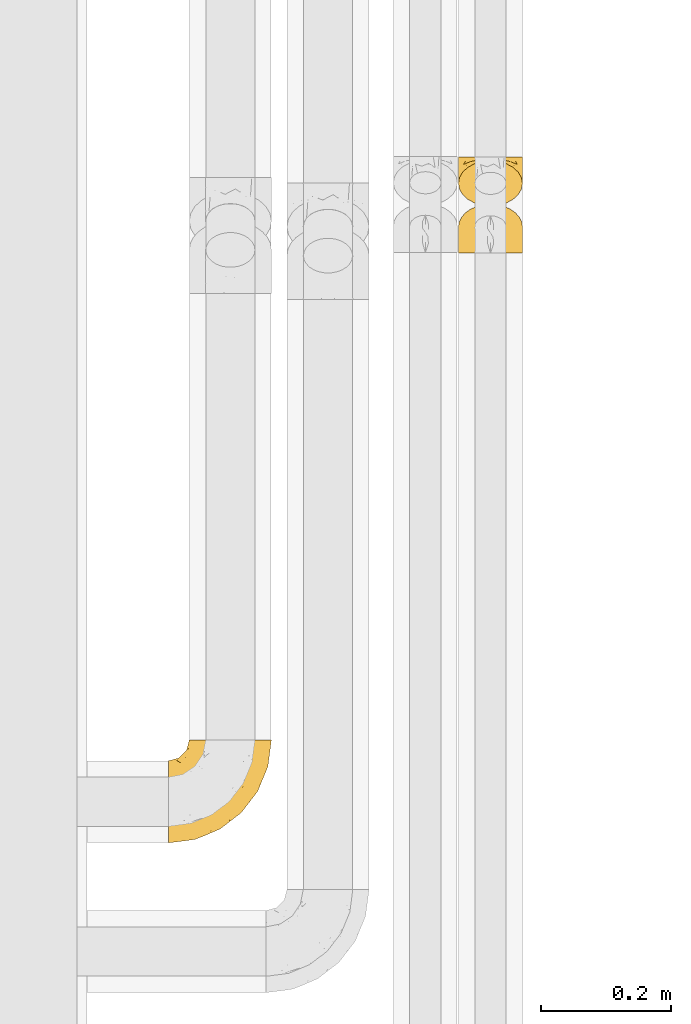
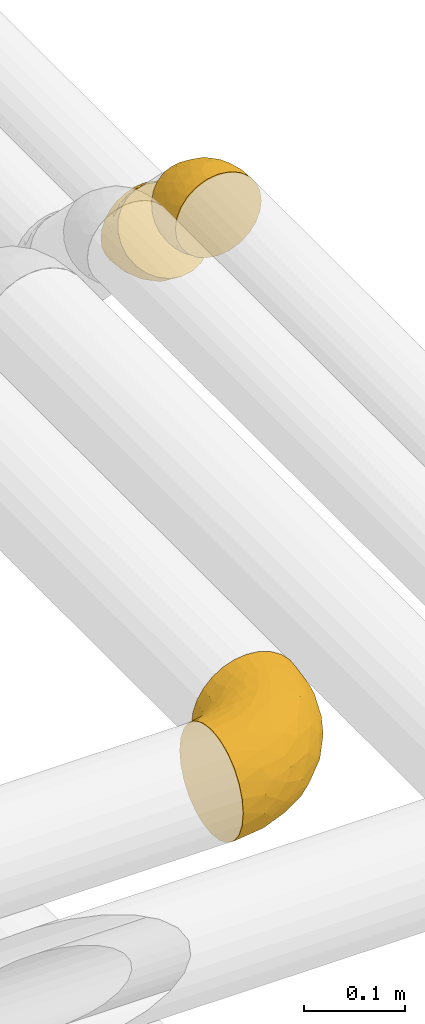
# One storey, part 488 of 827: 3 coverings.
"""IFC2X3 building model written with IfcOpenShell, lengths in millimetres."""

from ifc_helpers import new_model, entity, si_unit, converted_unit, derived_unit, direction, frame, origin, place, context, subcontext, project, spatial, faceted_brep, element, save


model = new_model("IFC2X3")

# Units and contexts
model_context = context("Model", 3, precision=0.01, world=origin(), true_north=direction((6.12303176911189e-17, 1.0)))
body_context = subcontext(model_context, "Body", "Model", "MODEL_VIEW")
ifc_project = project(units=[si_unit("LENGTHUNIT", "METRE", prefix="MILLI"), si_unit("AREAUNIT", "SQUARE_METRE"), si_unit("VOLUMEUNIT", "CUBIC_METRE"), converted_unit("PLANEANGLEUNIT", "DEGREE", entity("IfcRatioMeasure", 0.0174532925199433), si_unit("PLANEANGLEUNIT", "RADIAN"), dimensions=[0, 0, 0, 0, 0, 0, 0]), si_unit("MASSUNIT", "GRAM", prefix="KILO"), derived_unit("MASSDENSITYUNIT", [(si_unit("MASSUNIT", "GRAM", prefix="KILO"), 1), (si_unit("LENGTHUNIT", "METRE"), -3)]), derived_unit("MOMENTOFINERTIAUNIT", [(si_unit("LENGTHUNIT", "METRE"), 4)]), si_unit("TIMEUNIT", "SECOND"), si_unit("FREQUENCYUNIT", "HERTZ"), si_unit("THERMODYNAMICTEMPERATUREUNIT", "DEGREE_CELSIUS"), derived_unit("THERMALTRANSMITTANCEUNIT", [(si_unit("MASSUNIT", "GRAM", prefix="KILO"), 1), (si_unit("THERMODYNAMICTEMPERATUREUNIT", "KELVIN"), -1), (si_unit("TIMEUNIT", "SECOND"), -3)]), derived_unit("VOLUMETRICFLOWRATEUNIT", [(si_unit("LENGTHUNIT", "METRE"), 3), (si_unit("TIMEUNIT", "SECOND"), -1)]), derived_unit("MASSFLOWRATEUNIT", [(si_unit("MASSUNIT", "GRAM", prefix="KILO"), 1), (si_unit("TIMEUNIT", "SECOND"), -1)]), derived_unit("ROTATIONALFREQUENCYUNIT", [(si_unit("TIMEUNIT", "SECOND"), -1)]), si_unit("ELECTRICCURRENTUNIT", "AMPERE"), si_unit("ELECTRICVOLTAGEUNIT", "VOLT"), si_unit("POWERUNIT", "WATT"), si_unit("FORCEUNIT", "NEWTON", prefix="KILO"), si_unit("ILLUMINANCEUNIT", "LUX"), si_unit("LUMINOUSFLUXUNIT", "LUMEN"), si_unit("LUMINOUSINTENSITYUNIT", "CANDELA"), derived_unit("USERDEFINED", [(si_unit("MASSUNIT", "GRAM", prefix="KILO"), -1), (si_unit("LENGTHUNIT", "METRE"), -2), (si_unit("TIMEUNIT", "SECOND"), 3), (si_unit("LUMINOUSFLUXUNIT", "LUMEN"), 1)]), derived_unit("LINEARVELOCITYUNIT", [(si_unit("LENGTHUNIT", "METRE"), 1), (si_unit("TIMEUNIT", "SECOND"), -1)]), si_unit("PRESSUREUNIT", "PASCAL"), derived_unit("USERDEFINED", [(si_unit("LENGTHUNIT", "METRE"), -2), (si_unit("MASSUNIT", "GRAM", prefix="KILO"), 1), (si_unit("TIMEUNIT", "SECOND"), -2)]), derived_unit("LINEARFORCEUNIT", [(si_unit("MASSUNIT", "GRAM", prefix="KILO"), 1), (si_unit("LENGTHUNIT", "METRE"), 1), (si_unit("TIMEUNIT", "SECOND"), -2), (si_unit("LENGTHUNIT", "METRE"), -1)]), derived_unit("PLANARFORCEUNIT", [(si_unit("MASSUNIT", "GRAM", prefix="KILO"), 1), (si_unit("LENGTHUNIT", "METRE"), 1), (si_unit("TIMEUNIT", "SECOND"), -2), (si_unit("LENGTHUNIT", "METRE"), -2)])], contexts=[model_context])

# Site, building, storey
site_placement = place(None, origin())
site = spatial("IfcSite", under=ifc_project, at=site_placement, CompositionType="ELEMENT")
building_placement = place(site_placement, origin())
building = spatial("IfcBuilding", under=site, at=building_placement, CompositionType="ELEMENT")
storey_placement = place(building_placement, frame((0.0, 0.0, 28200.0)))
storey = spatial("IfcBuildingStorey", under=building, at=storey_placement, Name="08", CompositionType="ELEMENT", Elevation=28200.0)

# Coverings
covering_1_placement = place(storey_placement, frame((61101.89, 8151.26, 3046.96)))
element("IfcCovering", 1, at=covering_1_placement, inside=storey, Name=":ADSK_", ObjectType=":ADSK_", PredefinedType="INSULATION", context=body_context, shape_type="Brep", body=[
    faceted_brep([(20.09, 14.73, 9.18), (12.31, 20.24, 14.69), (6.46, 26.83, 21.28), (2.83, 34.17, 28.62), (1.6, 41.9, 36.35), (2.83, 49.64, 44.09), (6.47, 56.99, 51.43), (12.32, 63.57, 58.02), (20.11, 69.08, 63.53), (29.43, 73.22, 67.66), (39.81, 75.78, 70.23), (50.75, 76.65, 71.1), (61.69, 75.78, 70.23), (72.08, 73.21, 67.66), (81.4, 69.07, 63.52), (89.18, 63.56, 58.01), (95.03, 56.97, 51.42), (98.66, 49.63, 44.08), (99.9, 41.9, 36.35), (98.66, 34.16, 28.61), (95.02, 26.82, 21.26), (89.17, 20.23, 14.68), (81.38, 14.72, 9.17), (72.06, 10.59, 5.03), (61.68, 8.02, 2.47), (50.75, 7.15, 1.6), (39.8, 8.02, 2.47), (29.41, 10.59, 5.04), (63.47, 1.6, 5.57), (75.32, 1.6, 10.48), (85.5, 1.6, 18.29), (93.31, 1.6, 28.47), (98.22, 1.6, 40.32), (98.73, 1.6, 44.17), (99.9, 1.6, 53.04), (98.22, 1.6, 65.77), (93.31, 1.6, 77.62), (85.5, 1.6, 87.8), (75.32, 1.6, 95.61), (63.47, 1.6, 100.52), (50.75, 1.6, 102.19), (38.02, 1.6, 100.52), (26.17, 1.6, 95.61), (15.99, 1.6, 87.8), (8.18, 1.6, 77.62), (3.27, 1.6, 65.77), (1.6, 1.6, 53.04), (2.76, 1.6, 44.17), (3.27, 1.6, 40.32), (5.73, 1.6, 34.4), (8.18, 1.6, 28.47), (15.99, 1.6, 18.29), (26.17, 1.6, 10.48), (38.02, 1.6, 5.57), (50.75, 1.6, 3.89), (17.06, 50.76, 74.74), (50.75, 29.07, 98.58), (42.16, 19.13, 99.97), (21.74, 20.34, 90.89), (32.73, 22.35, 96.66), (26.38, 40.28, 87.92), (13.88, 19.78, 83.69), (40.98, 40.29, 93.84), (10.72, 34.98, 74.79), (18.26, 35.02, 83.78), (5.11, 38.13, 61.84), (6.1, 19.63, 71.48), (2.75, 22.22, 60.43), (2.16, 35.73, 50.66), (1.6, 23.41, 48.71), (25.58, 57.96, 77.7), (35.33, 56.93, 83.71), (50.75, 54.67, 87.97), (9.83, 49.84, 65.09), (1.6, 17.92, 49.8), (1.6, 12.43, 50.89), (1.6, 9.72, 51.43), (1.6, 7.01, 51.97), (1.6, 37.31, 39.42), (1.6, 32.71, 42.49), (1.6, 28.06, 45.6), (31.89, 6.25, 6.68), (3.63, 16.23, 36.5), (3.42, 9.32, 39.08), (2.64, 22.66, 37.99), (5.35, 18.11, 30.45), (19.98, 9.02, 13.18), (14.31, 7.35, 19.36), (9.44, 13.47, 23.98), (2.88, 6.24, 41.63), (2.5, 31.3, 33.28), (2.44, 27.55, 36.3), (41.56, 4.74, 4.17), (8.24, 8.06, 27.71), (12.78, 15.85, 17.53), (5.31, 22.07, 28.35), (50.75, 4.6, 3.3), (87.18, 7.35, 19.35), (81.5, 9.01, 13.16), (93.25, 8.06, 27.71), (59.93, 4.74, 4.17), (69.59, 6.25, 6.67), (99.9, 37.31, 39.42), (92.03, 13.46, 23.96), (99.9, 7.01, 51.97), (99.1, 7.26, 43.92), (88.7, 15.84, 17.52), (98.07, 9.32, 39.08), (99.9, 23.41, 48.71), (97.86, 16.24, 36.48), (98.85, 22.65, 37.98), (99.9, 17.92, 49.8), (96.17, 22.05, 28.33), (99.9, 32.71, 42.49), (98.99, 31.3, 33.28), (99.04, 27.55, 36.29), (96.14, 18.09, 30.44), (99.9, 28.06, 45.6), (99.9, 12.43, 50.89), (96.38, 38.12, 61.83), (98.74, 22.22, 60.43), (84.45, 50.76, 74.73), (95.4, 19.61, 71.47), (90.78, 34.97, 74.77), (60.07, 27.94, 97.95), (68.76, 22.36, 96.65), (79.75, 20.34, 90.89), (75.13, 40.28, 87.91), (99.34, 35.73, 50.65), (87.61, 19.78, 83.69), (91.67, 49.83, 65.08), (65.98, 40.09, 92.37), (66.17, 56.93, 83.71), (75.92, 57.95, 77.7), (83.22, 35.02, 83.78)], [[[0, 1, 2, 3, 4, 5, 6, 7, 8, 9, 10, 11, 12, 13, 14, 15, 16, 17, 18, 19, 20, 21, 22, 23, 24, 25, 26, 27]], [[28, 29, 30, 31, 32, 33, 34, 35, 36, 37, 38, 39, 40, 41, 42, 43, 44, 45, 46, 47, 48, 49, 50, 51, 52, 53, 54]], [[7, 55, 8]], [[40, 56, 57]], [[42, 58, 43]], [[59, 60, 58]], [[61, 44, 43]], [[60, 59, 62]], [[63, 61, 64]], [[63, 65, 66]], [[67, 46, 45]], [[66, 67, 45]], [[42, 41, 59]], [[67, 68, 69]], [[58, 61, 43]], [[70, 60, 71]], [[71, 62, 72]], [[72, 10, 71]], [[55, 70, 8]], [[9, 70, 71]], [[59, 58, 42]], [[11, 10, 72]], [[73, 55, 7]], [[67, 69, 74, 75, 76, 77, 46]], [[41, 57, 59]], [[68, 4, 78, 79, 80, 69]], [[6, 5, 65]], [[73, 65, 63]], [[45, 44, 66]], [[67, 66, 65]], [[6, 73, 7]], [[57, 62, 59]], [[68, 65, 5]], [[9, 71, 10]], [[60, 55, 64]], [[66, 44, 61]], [[64, 61, 58]], [[61, 63, 66]], [[60, 64, 58]], [[63, 64, 55]], [[65, 73, 6]], [[55, 73, 63]], [[65, 68, 67]], [[4, 68, 5]], [[8, 70, 9]], [[55, 60, 70]], [[40, 57, 41]], [[62, 57, 56]], [[72, 62, 56]], [[62, 71, 60]], [[52, 81, 53]], [[82, 83, 74]], [[84, 85, 82]], [[86, 87, 88]], [[77, 89, 48]], [[87, 52, 51]], [[90, 2, 91]], [[92, 26, 25]], [[86, 27, 81]], [[54, 53, 92]], [[52, 86, 81]], [[93, 51, 50]], [[87, 51, 93]], [[83, 93, 50]], [[94, 95, 1]], [[2, 1, 95]], [[2, 95, 91]], [[4, 3, 78]], [[94, 88, 85]], [[86, 94, 0]], [[48, 47, 46, 77]], [[96, 92, 25]], [[80, 91, 84]], [[27, 26, 81]], [[0, 27, 86]], [[90, 78, 3]], [[26, 92, 81]], [[94, 86, 88]], [[82, 93, 83]], [[0, 94, 1]], [[80, 84, 69]], [[82, 88, 93]], [[49, 48, 89]], [[69, 82, 74]], [[83, 75, 74]], [[88, 87, 93]], [[52, 87, 86]], [[91, 80, 79]], [[91, 79, 90]], [[84, 91, 95]], [[85, 84, 95]], [[69, 84, 82]], [[78, 90, 79]], [[2, 90, 3]], [[94, 85, 95]], [[82, 85, 88]], [[54, 92, 96]], [[81, 92, 53]], [[83, 89, 75]], [[77, 76, 75, 89]], [[83, 49, 89]], [[83, 50, 49]], [[97, 29, 98]], [[30, 99, 31]], [[100, 101, 28]], [[19, 18, 102]], [[103, 99, 97]], [[101, 29, 28]], [[104, 33, 105]], [[98, 106, 103]], [[107, 31, 99]], [[97, 99, 30]], [[108, 109, 110]], [[23, 98, 101]], [[54, 96, 100]], [[109, 111, 107]], [[25, 24, 100]], [[112, 106, 21]], [[101, 24, 23]], [[102, 113, 114]], [[105, 31, 107]], [[22, 98, 23]], [[21, 106, 22]], [[112, 21, 20]], [[106, 98, 22]], [[20, 19, 114]], [[112, 115, 110]], [[113, 115, 114]], [[29, 101, 98]], [[112, 116, 106]], [[29, 97, 30]], [[96, 25, 100]], [[115, 113, 117]], [[103, 109, 99]], [[109, 107, 99]], [[105, 107, 118]], [[111, 109, 108]], [[111, 118, 107]], [[103, 97, 98]], [[110, 116, 112]], [[110, 115, 117]], [[20, 115, 112]], [[108, 110, 117]], [[116, 109, 103]], [[20, 114, 115]], [[102, 114, 19]], [[109, 116, 110]], [[106, 116, 103]], [[104, 34, 33]], [[33, 32, 105]], [[101, 100, 24]], [[54, 100, 28]], [[104, 105, 118]], [[31, 105, 32]], [[17, 16, 119]], [[35, 34, 120]], [[120, 34, 104, 118, 111, 108]], [[121, 15, 14]], [[36, 35, 122]], [[122, 119, 123]], [[39, 124, 40]], [[125, 126, 127]], [[125, 39, 38]], [[128, 120, 108]], [[129, 36, 122]], [[38, 126, 125]], [[129, 126, 37]], [[37, 126, 38]], [[120, 128, 119]], [[35, 120, 122]], [[119, 16, 130]], [[131, 127, 132]], [[130, 16, 15]], [[133, 14, 13]], [[134, 127, 126]], [[123, 130, 121]], [[125, 127, 131]], [[13, 132, 133]], [[12, 11, 72]], [[72, 56, 124]], [[12, 72, 132]], [[133, 132, 127]], [[123, 129, 122]], [[12, 132, 13]], [[119, 122, 120]], [[128, 18, 17]], [[39, 125, 124]], [[126, 129, 134]], [[36, 129, 37]], [[134, 123, 121]], [[123, 134, 129]], [[127, 134, 121]], [[121, 130, 15]], [[119, 130, 123]], [[128, 108, 117, 113, 102, 18]], [[119, 128, 17]], [[127, 121, 133]], [[14, 133, 121]], [[72, 131, 132]], [[124, 125, 131]], [[72, 124, 131]], [[124, 56, 40]]]),
])
covering_2_placement = place(storey_placement, frame((61101.89, 8223.68, 2949.0)))
element("IfcCovering", 2, at=covering_2_placement, inside=storey, Name=":ADSK_", ObjectType=":ADSK_", PredefinedType="INSULATION", context=body_context, shape_type="Brep", body=[
    faceted_brep([(50.75, 76.65, 99.9), (61.69, 76.65, 98.66), (72.08, 76.65, 95.02), (81.4, 76.65, 89.17), (89.18, 76.65, 81.38), (95.03, 76.65, 72.06), (98.66, 76.65, 61.68), (99.9, 76.65, 50.75), (98.66, 76.65, 39.8), (95.02, 76.65, 29.41), (89.17, 76.65, 20.09), (81.38, 76.65, 12.31), (72.06, 76.65, 6.46), (61.68, 76.65, 2.83), (50.75, 76.65, 1.6), (39.8, 76.65, 2.83), (29.41, 76.65, 6.47), (20.09, 76.65, 12.32), (12.31, 76.65, 20.11), (6.46, 76.65, 29.43), (2.83, 76.65, 39.81), (1.6, 76.65, 50.75), (2.83, 76.65, 61.69), (6.47, 76.65, 72.08), (12.32, 76.65, 81.4), (20.11, 76.65, 89.18), (29.43, 76.65, 95.03), (39.81, 76.65, 98.66), (38.02, 69.92, 101.01), (26.17, 66.45, 97.54), (15.99, 60.92, 92.02), (8.18, 53.73, 84.82), (3.27, 45.34, 76.44), (2.76, 42.63, 73.72), (1.6, 36.35, 67.44), (3.27, 27.35, 58.45), (8.18, 18.97, 50.06), (15.99, 11.77, 42.87), (26.17, 6.25, 37.34), (38.02, 2.78, 33.87), (50.75, 1.6, 32.69), (63.47, 2.78, 33.87), (75.32, 6.25, 37.34), (85.5, 11.77, 42.87), (93.31, 18.97, 50.06), (98.22, 27.35, 58.45), (99.9, 36.35, 67.44), (98.73, 42.63, 73.72), (98.22, 45.34, 76.44), (95.77, 49.54, 80.63), (93.31, 53.73, 84.82), (85.5, 60.92, 92.02), (75.32, 66.45, 97.54), (63.47, 69.92, 101.01), (50.75, 71.1, 102.19), (84.43, 55.78, 17.34), (50.75, 23.58, 15.82), (59.33, 15.57, 21.86), (79.75, 22.85, 27.43), (68.76, 20.19, 21.92), (75.11, 39.05, 15.43), (87.61, 27.54, 32.91), (60.52, 34.86, 11.24), (90.77, 44.58, 28.46), (83.23, 38.25, 22.07), (96.38, 55.96, 35.39), (95.39, 36.06, 41.65), (98.74, 45.71, 47.63), (99.33, 62.18, 44.99), (99.9, 54.84, 55.08), (75.91, 58.77, 10.15), (66.16, 53.8, 6.63), (50.75, 49.18, 5.21), (91.66, 61.94, 24.81), (99.9, 50.19, 58.19), (99.9, 45.54, 61.3), (99.9, 43.24, 62.84), (99.9, 40.94, 64.37), (99.9, 71.24, 51.82), (99.9, 65.82, 52.9), (99.9, 60.33, 53.99), (69.6, 72.43, 96.93), (97.86, 58.4, 68.79), (98.07, 51.68, 71.85), (98.85, 61.89, 63.19), (96.14, 64.0, 71.74), (81.51, 69.79, 90.38), (87.18, 64.24, 87.19), (92.05, 65.3, 79.59), (98.61, 47.71, 72.23), (98.99, 71.33, 60.42), (99.05, 66.54, 60.92), (59.93, 73.13, 99.77), (93.25, 58.83, 80.78), (88.71, 71.54, 82.47), (96.18, 68.29, 70.43), (50.75, 73.65, 100.49), (14.31, 64.24, 87.19), (19.99, 69.79, 90.39), (8.24, 58.83, 80.78), (41.56, 73.13, 99.78), (31.91, 72.43, 96.94), (1.6, 71.24, 51.82), (9.46, 65.31, 79.62), (1.6, 40.94, 64.37), (2.39, 46.81, 69.89), (12.79, 71.54, 82.49), (3.42, 51.68, 71.85), (1.6, 54.84, 55.08), (3.63, 58.41, 68.8), (2.64, 61.89, 63.2), (1.6, 50.19, 58.19), (5.32, 68.29, 70.45), (1.6, 65.82, 52.9), (2.5, 71.32, 60.41), (2.45, 66.55, 60.94), (5.35, 64.0, 71.76), (1.6, 60.33, 53.99), (1.6, 45.54, 61.3), (5.11, 55.96, 35.4), (2.75, 45.71, 47.64), (17.04, 55.78, 17.35), (6.1, 36.06, 41.67), (10.71, 44.59, 28.47), (41.42, 23.23, 17.06), (32.73, 20.2, 21.92), (21.74, 22.84, 27.43), (26.36, 39.05, 15.44), (2.16, 62.18, 44.99), (13.88, 27.54, 32.91), (9.82, 61.95, 24.82), (35.51, 35.76, 12.42), (35.32, 53.79, 6.63), (25.57, 58.77, 10.16), (18.27, 38.25, 22.07)], [[[0, 1, 2, 3, 4, 5, 6, 7, 8, 9, 10, 11, 12, 13, 14, 15, 16, 17, 18, 19, 20, 21, 22, 23, 24, 25, 26, 27]], [[28, 29, 30, 31, 32, 33, 34, 35, 36, 37, 38, 39, 40, 41, 42, 43, 44, 45, 46, 47, 48, 49, 50, 51, 52, 53, 54]], [[10, 55, 11]], [[40, 56, 57]], [[42, 58, 43]], [[59, 60, 58]], [[61, 44, 43]], [[60, 59, 62]], [[63, 61, 64]], [[63, 65, 66]], [[67, 46, 45]], [[66, 67, 45]], [[42, 41, 59]], [[67, 68, 69]], [[58, 61, 43]], [[70, 60, 71]], [[71, 62, 72]], [[72, 13, 71]], [[55, 70, 11]], [[12, 70, 71]], [[59, 58, 42]], [[14, 13, 72]], [[73, 55, 10]], [[67, 69, 74, 75, 76, 77, 46]], [[41, 57, 59]], [[68, 7, 78, 79, 80, 69]], [[9, 8, 65]], [[73, 65, 63]], [[45, 44, 66]], [[67, 66, 65]], [[9, 73, 10]], [[57, 62, 59]], [[68, 65, 8]], [[12, 71, 13]], [[60, 55, 64]], [[66, 44, 61]], [[64, 61, 58]], [[61, 63, 66]], [[60, 64, 58]], [[63, 64, 55]], [[65, 73, 9]], [[55, 73, 63]], [[65, 68, 67]], [[7, 68, 8]], [[11, 70, 12]], [[55, 60, 70]], [[40, 57, 41]], [[62, 57, 56]], [[72, 62, 56]], [[62, 71, 60]], [[52, 81, 53]], [[82, 83, 74]], [[84, 85, 82]], [[86, 87, 88]], [[77, 89, 48]], [[87, 52, 51]], [[90, 5, 91]], [[92, 1, 0]], [[86, 2, 81]], [[54, 53, 92]], [[52, 86, 81]], [[93, 51, 50]], [[87, 51, 93]], [[83, 93, 50]], [[94, 95, 4]], [[5, 4, 95]], [[5, 95, 91]], [[7, 6, 78]], [[94, 88, 85]], [[86, 94, 3]], [[48, 47, 46, 77]], [[96, 92, 0]], [[80, 91, 84]], [[2, 1, 81]], [[3, 2, 86]], [[90, 78, 6]], [[1, 92, 81]], [[94, 86, 88]], [[82, 93, 83]], [[3, 94, 4]], [[80, 84, 69]], [[82, 88, 93]], [[49, 48, 89]], [[69, 82, 74]], [[83, 75, 74]], [[88, 87, 93]], [[52, 87, 86]], [[91, 80, 79]], [[91, 79, 90]], [[84, 91, 95]], [[85, 84, 95]], [[69, 84, 82]], [[78, 90, 79]], [[5, 90, 6]], [[94, 85, 95]], [[82, 85, 88]], [[54, 92, 96]], [[81, 92, 53]], [[83, 89, 75]], [[77, 76, 75, 89]], [[83, 49, 89]], [[83, 50, 49]], [[97, 29, 98]], [[30, 99, 31]], [[100, 101, 28]], [[22, 21, 102]], [[103, 99, 97]], [[101, 29, 28]], [[104, 33, 105]], [[98, 106, 103]], [[107, 31, 99]], [[97, 99, 30]], [[108, 109, 110]], [[26, 98, 101]], [[54, 96, 100]], [[109, 111, 107]], [[0, 27, 100]], [[112, 106, 24]], [[101, 27, 26]], [[102, 113, 114]], [[105, 31, 107]], [[25, 98, 26]], [[24, 106, 25]], [[112, 24, 23]], [[106, 98, 25]], [[23, 22, 114]], [[112, 115, 110]], [[113, 115, 114]], [[29, 101, 98]], [[112, 116, 106]], [[29, 97, 30]], [[96, 0, 100]], [[115, 113, 117]], [[103, 109, 99]], [[109, 107, 99]], [[105, 107, 118]], [[111, 109, 108]], [[111, 118, 107]], [[103, 97, 98]], [[110, 116, 112]], [[110, 115, 117]], [[23, 115, 112]], [[108, 110, 117]], [[116, 109, 103]], [[23, 114, 115]], [[102, 114, 22]], [[109, 116, 110]], [[106, 116, 103]], [[104, 34, 33]], [[33, 32, 105]], [[101, 100, 27]], [[54, 100, 28]], [[104, 105, 118]], [[31, 105, 32]], [[20, 19, 119]], [[35, 34, 120]], [[120, 34, 104, 118, 111, 108]], [[121, 18, 17]], [[36, 35, 122]], [[122, 119, 123]], [[39, 124, 40]], [[125, 126, 127]], [[125, 39, 38]], [[128, 120, 108]], [[129, 36, 122]], [[38, 126, 125]], [[129, 126, 37]], [[37, 126, 38]], [[120, 128, 119]], [[35, 120, 122]], [[119, 19, 130]], [[131, 127, 132]], [[130, 19, 18]], [[133, 17, 16]], [[134, 127, 126]], [[123, 130, 121]], [[125, 127, 131]], [[16, 132, 133]], [[15, 14, 72]], [[72, 56, 124]], [[15, 72, 132]], [[133, 132, 127]], [[123, 129, 122]], [[15, 132, 16]], [[119, 122, 120]], [[128, 21, 20]], [[39, 125, 124]], [[126, 129, 134]], [[36, 129, 37]], [[134, 123, 121]], [[123, 134, 129]], [[127, 134, 121]], [[121, 130, 18]], [[119, 130, 123]], [[128, 108, 117, 113, 102, 21]], [[119, 128, 20]], [[127, 121, 133]], [[17, 133, 121]], [[72, 131, 132]], [[124, 125, 131]], [[72, 124, 131]], [[124, 56, 40]]]),
])
covering_3_placement = place(storey_placement, frame((60656.51, 7245.35, 3035.35)))
element("IfcCovering", 3, at=covering_3_placement, inside=storey, Name=":ADSK_", ObjectType=":ADSK_", PredefinedType="INSULATION", context=body_context, shape_type="Brep", body=[
    faceted_brep([(110.62, 159.65, 126.11), (123.95, 159.65, 121.45), (135.9, 159.65, 113.94), (145.89, 159.65, 103.96), (153.4, 159.65, 92.0), (158.06, 159.65, 78.68), (159.65, 159.65, 64.65), (158.06, 159.65, 50.62), (153.4, 159.65, 37.29), (145.89, 159.65, 25.34), (135.91, 159.65, 15.35), (123.95, 159.65, 7.84), (110.63, 159.65, 3.18), (96.6, 159.65, 1.6), (82.57, 159.65, 3.18), (69.24, 159.65, 7.84), (57.29, 159.65, 15.35), (47.3, 159.65, 25.33), (39.79, 159.65, 37.29), (35.13, 159.65, 50.61), (33.55, 159.65, 64.65), (35.13, 159.65, 78.67), (39.79, 159.65, 92.0), (47.3, 159.65, 103.95), (57.28, 159.65, 113.94), (69.24, 159.65, 121.45), (82.56, 159.65, 126.11), (96.6, 159.65, 127.7), (1.6, 127.7, 64.65), (1.6, 125.55, 48.33), (1.6, 119.25, 33.12), (1.6, 109.23, 20.06), (1.6, 96.17, 10.04), (1.6, 80.96, 3.74), (1.6, 75.35, 3.01), (1.6, 64.65, 1.6), (1.6, 48.33, 3.74), (1.6, 33.12, 10.04), (1.6, 20.06, 20.06), (1.6, 10.04, 33.12), (1.6, 3.74, 48.33), (1.6, 1.6, 64.65), (1.6, 3.74, 80.96), (1.6, 10.04, 96.17), (1.6, 20.06, 109.23), (1.6, 33.12, 119.25), (1.6, 48.33, 125.55), (1.6, 64.65, 127.7), (1.6, 75.35, 126.29), (1.6, 80.96, 125.55), (1.6, 96.17, 119.25), (1.6, 109.23, 109.23), (1.6, 119.25, 96.17), (1.6, 125.55, 80.96), (30.13, 16.01, 101.1), (39.4, 10.29, 86.72), (62.65, 24.76, 98.7), (28.52, 4.94, 75.93), (42.5, 6.98, 64.65), (115.57, 87.32, 113.39), (98.94, 62.3, 111.06), (111.29, 58.52, 96.87), (95.5, 36.35, 84.07), (80.62, 22.77, 64.65), (113.35, 47.89, 64.65), (43.71, 40.91, 119.56), (70.76, 42.82, 112.75), (62.71, 57.25, 122.85), (33.16, 51.19, 125.08), (53.41, 66.64, 126.64), (130.65, 98.56, 105.78), (137.68, 94.44, 93.81), (146.84, 123.53, 96.07), (66.58, 20.12, 87.11), (57.7, 12.95, 75.77), (39.88, 28.48, 111.99), (154.26, 118.74, 64.65), (152.07, 121.88, 83.58), (125.54, 65.08, 80.96), (142.81, 92.08, 78.34), (103.99, 98.53, 122.85), (79.4, 81.84, 125.88), (88.81, 72.43, 120.97), (104.86, 134.31, 126.67), (117.38, 129.11, 122.64), (57.43, 82.79, 127.7), (44.19, 76.04, 127.7), (30.95, 69.29, 127.7), (139.96, 129.58, 107.12), (127.03, 115.86, 115.07), (87.17, 42.36, 102.81), (78.45, 103.81, 127.7), (73.2, 98.55, 127.7), (67.94, 93.3, 127.7), (94.63, 147.25, 127.7), (93.29, 138.77, 127.7), (91.95, 130.29, 127.7), (94.6, 107.83, 126.64), (85.2, 117.05, 127.7), (138.47, 80.62, 64.65), (13.99, 66.61, 127.7), (40.46, 121.29, 113.05), (32.36, 128.09, 101.81), (28.71, 118.04, 108.46), (15.53, 79.47, 126.21), (29.06, 94.94, 122.65), (40.03, 86.01, 126.55), (45.36, 94.69, 125.45), (26.46, 83.06, 126.01), (47.56, 104.39, 123.3), (36.28, 107.01, 118.99), (55.57, 148.3, 113.51), (45.02, 143.82, 104.6), (57.55, 134.19, 118.04), (11.56, 116.87, 101.6), (19.2, 111.58, 109.98), (10.07, 122.36, 92.1), (21.04, 124.16, 96.28), (15.52, 94.28, 121.05), (13.84, 128.25, 79.4), (32.67, 146.72, 79.19), (24.86, 134.92, 80.39), (34.31, 138.87, 93.14), (81.47, 133.28, 126.75), (71.26, 121.77, 125.71), (81.64, 145.83, 126.17), (29.26, 143.67, 64.65), (70.65, 139.93, 123.28), (31.93, 153.63, 64.65), (27.99, 132.32, 91.58), (41.71, 132.59, 107.1), (50.14, 126.42, 116.28), (17.57, 102.97, 116.32), (37.62, 149.52, 90.34), (60.48, 120.88, 122.74), (17.57, 131.98, 64.65), (56.96, 96.12, 126.77), (48.98, 115.84, 119.84), (57.29, 108.2, 124.71), (68.25, 110.85, 126.47), (10.07, 122.36, 37.19), (16.58, 118.35, 27.66), (13.84, 128.25, 49.9), (13.99, 66.61, 1.6), (32.67, 146.72, 50.1), (24.86, 134.92, 48.89), (67.81, 110.73, 2.88), (61.09, 121.83, 6.55), (71.26, 121.77, 3.58), (57.43, 82.79, 1.6), (44.19, 76.04, 1.6), (40.03, 86.01, 2.74), (57.55, 134.19, 11.25), (51.01, 124.9, 11.93), (42.79, 132.35, 21.09), (26.46, 83.06, 3.28), (29.06, 94.94, 6.64), (17.57, 102.97, 12.97), (19.2, 111.58, 19.31), (40.46, 121.29, 16.23), (28.84, 118.82, 21.44), (33.48, 128.68, 26.96), (15.52, 94.28, 8.24), (15.53, 79.47, 3.08), (36.28, 107.01, 10.3), (37.62, 149.51, 38.95), (21.04, 124.16, 33.01), (94.63, 147.25, 1.6), (93.29, 138.77, 1.6), (34.31, 138.87, 36.15), (45.03, 143.82, 24.69), (70.65, 139.92, 6.01), (81.47, 133.28, 2.54), (55.58, 148.3, 15.78), (91.95, 130.29, 1.6), (81.64, 145.83, 3.12), (27.86, 131.94, 37.33), (78.45, 103.81, 1.6), (85.2, 117.05, 1.6), (56.96, 96.12, 2.52), (45.36, 94.69, 3.84), (47.57, 104.39, 5.99), (48.27, 114.83, 9.35), (67.94, 93.3, 1.6), (57.3, 108.2, 4.58), (30.95, 69.29, 1.6), (62.65, 24.76, 30.59), (30.13, 16.01, 28.19), (39.88, 28.48, 17.3), (43.71, 40.91, 9.73), (39.4, 10.29, 42.57), (55.79, 12.23, 53.51), (28.41, 4.91, 53.42), (53.41, 66.64, 2.65), (104.86, 134.31, 2.62), (117.39, 129.11, 6.66), (103.99, 98.53, 6.44), (125.54, 65.08, 48.33), (111.29, 58.52, 32.42), (137.69, 94.45, 35.49), (94.6, 107.83, 2.65), (79.4, 81.84, 3.41), (33.16, 51.19, 4.21), (68.78, 20.8, 43.07), (130.66, 98.56, 23.52), (139.97, 129.58, 22.18), (148.6, 131.93, 33.1), (115.58, 87.32, 15.9), (127.03, 115.86, 14.23), (70.76, 42.82, 16.54), (95.5, 36.35, 45.22), (62.71, 57.25, 6.44), (88.81, 72.43, 8.33), (98.94, 62.3, 18.23), (89.09, 38.39, 32.99), (78.72, 22.86, 53.35), (142.21, 92.06, 48.76), (152.07, 121.88, 45.72)], [[[0, 1, 2, 3, 4, 5, 6, 7, 8, 9, 10, 11, 12, 13, 14, 15, 16, 17, 18, 19, 20, 21, 22, 23, 24, 25, 26, 27]], [[28, 29, 30, 31, 32, 33, 34, 35, 36, 37, 38, 39, 40, 41, 42, 43, 44, 45, 46, 47, 48, 49, 50, 51, 52, 53]], [[54, 55, 56]], [[57, 41, 58]], [[59, 60, 61]], [[62, 63, 64]], [[65, 66, 67]], [[68, 67, 69]], [[70, 71, 72]], [[55, 73, 56]], [[43, 42, 55]], [[55, 74, 73]], [[44, 75, 45]], [[44, 43, 54]], [[76, 5, 77]], [[71, 78, 79]], [[45, 75, 65]], [[46, 68, 47]], [[80, 81, 82]], [[0, 83, 84]], [[69, 85, 86, 87]], [[69, 81, 85]], [[84, 1, 0]], [[2, 88, 3]], [[4, 3, 72]], [[44, 54, 75]], [[5, 4, 77]], [[89, 2, 1]], [[72, 3, 88]], [[5, 76, 6]], [[70, 88, 89]], [[68, 65, 67]], [[88, 2, 89]], [[56, 90, 66]], [[64, 78, 62]], [[81, 91, 92, 93, 85]], [[83, 27, 94, 95, 96]], [[62, 61, 90]], [[97, 96, 98, 91]], [[80, 97, 81]], [[42, 57, 55]], [[62, 78, 61]], [[84, 89, 1]], [[78, 64, 99]], [[57, 74, 55]], [[76, 77, 79]], [[77, 72, 71]], [[82, 81, 67]], [[97, 83, 96]], [[80, 89, 84]], [[79, 78, 99]], [[71, 70, 61]], [[81, 97, 91]], [[83, 80, 84]], [[68, 87, 100, 47]], [[81, 69, 67]], [[68, 69, 87]], [[65, 46, 45]], [[65, 68, 46]], [[66, 65, 75]], [[56, 66, 75]], [[66, 60, 82]], [[71, 61, 78]], [[60, 66, 90]], [[83, 97, 80]], [[27, 83, 0]], [[59, 70, 89]], [[70, 59, 61]], [[89, 80, 59]], [[82, 59, 80]], [[55, 54, 43]], [[75, 54, 56]], [[66, 82, 67]], [[59, 82, 60]], [[41, 57, 42]], [[74, 57, 58]], [[58, 63, 74]], [[62, 74, 63]], [[74, 62, 73]], [[62, 56, 73]], [[4, 72, 77]], [[70, 72, 88]], [[76, 79, 99]], [[71, 79, 77]], [[62, 90, 56]], [[60, 90, 61]], [[101, 102, 103]], [[100, 87, 104]], [[105, 106, 107]], [[108, 104, 87]], [[107, 109, 110]], [[108, 87, 86]], [[111, 112, 113]], [[114, 51, 115]], [[116, 114, 117]], [[51, 50, 118]], [[119, 28, 53]], [[120, 121, 122]], [[98, 123, 124]], [[125, 96, 95]], [[116, 53, 52]], [[126, 121, 120]], [[104, 108, 118]], [[98, 124, 91]], [[25, 24, 127]], [[120, 128, 126]], [[122, 129, 102]], [[95, 94, 27, 26]], [[122, 102, 130]], [[125, 127, 123]], [[24, 111, 127]], [[21, 20, 128]], [[112, 130, 131]], [[48, 47, 100, 49]], [[132, 110, 115]], [[23, 111, 24]], [[129, 119, 117]], [[120, 133, 21]], [[112, 23, 22]], [[134, 113, 131]], [[121, 126, 135]], [[133, 112, 22]], [[128, 120, 21]], [[132, 51, 118]], [[120, 122, 133]], [[119, 121, 135]], [[129, 117, 102]], [[125, 26, 25]], [[26, 125, 95]], [[127, 125, 25]], [[28, 119, 135]], [[119, 53, 116]], [[127, 113, 124]], [[96, 125, 123]], [[112, 131, 113]], [[101, 103, 110]], [[85, 93, 136]], [[124, 123, 127]], [[98, 96, 123]], [[112, 111, 23]], [[127, 111, 113]], [[112, 133, 122]], [[21, 133, 22]], [[107, 110, 105]], [[110, 109, 137]], [[86, 106, 108]], [[138, 109, 136]], [[105, 118, 108]], [[107, 106, 85]], [[104, 50, 49]], [[124, 134, 139]], [[138, 93, 92]], [[92, 91, 139]], [[100, 104, 49]], [[118, 105, 132]], [[104, 118, 50]], [[110, 132, 105]], [[51, 132, 115]], [[108, 106, 105]], [[85, 106, 86]], [[114, 116, 52]], [[119, 116, 117]], [[51, 114, 52]], [[114, 115, 103]], [[117, 114, 103]], [[130, 102, 101]], [[117, 103, 102]], [[110, 103, 115]], [[130, 101, 131]], [[122, 130, 112]], [[101, 137, 131]], [[113, 134, 124]], [[137, 134, 131]], [[124, 139, 91]], [[134, 138, 139]], [[92, 139, 138]], [[110, 137, 101]], [[134, 137, 138]], [[136, 109, 107]], [[137, 109, 138]], [[85, 136, 107]], [[138, 136, 93]], [[122, 121, 129]], [[129, 121, 119]], [[30, 140, 141]], [[30, 29, 140]], [[28, 135, 142]], [[143, 35, 34, 33]], [[19, 144, 128]], [[126, 145, 135]], [[146, 147, 148]], [[149, 150, 151]], [[152, 153, 154]], [[155, 156, 151]], [[157, 31, 158]], [[159, 160, 161]], [[32, 162, 163]], [[158, 31, 30]], [[157, 164, 156]], [[126, 144, 145]], [[126, 128, 144]], [[18, 165, 19]], [[141, 166, 160]], [[14, 13, 167, 168]], [[163, 143, 33]], [[169, 165, 170]], [[18, 17, 170]], [[153, 159, 154]], [[142, 135, 145]], [[148, 171, 172]], [[159, 161, 154]], [[171, 152, 173]], [[173, 17, 16]], [[16, 15, 171]], [[158, 160, 164]], [[174, 175, 168]], [[173, 170, 17]], [[19, 128, 20]], [[174, 172, 175]], [[165, 169, 144]], [[162, 157, 156]], [[175, 172, 171]], [[144, 169, 145]], [[176, 169, 161]], [[166, 140, 142]], [[175, 171, 15]], [[168, 175, 14]], [[14, 175, 15]], [[142, 145, 176]], [[28, 142, 29]], [[148, 177, 146]], [[148, 178, 177]], [[152, 171, 148]], [[179, 180, 181]], [[164, 180, 156]], [[174, 178, 172]], [[148, 172, 178]], [[171, 173, 16]], [[170, 173, 152]], [[19, 165, 144]], [[170, 165, 18]], [[153, 182, 159]], [[146, 183, 184]], [[181, 180, 164]], [[180, 151, 156]], [[163, 155, 185]], [[155, 150, 185]], [[162, 156, 155]], [[143, 163, 185]], [[180, 179, 149]], [[32, 163, 33]], [[163, 162, 155]], [[31, 162, 32]], [[31, 157, 162]], [[164, 157, 158]], [[149, 151, 180]], [[155, 151, 150]], [[142, 140, 29]], [[141, 140, 166]], [[176, 145, 169]], [[30, 141, 158]], [[164, 160, 159]], [[158, 141, 160]], [[166, 161, 160]], [[154, 169, 170]], [[169, 154, 161]], [[152, 154, 170]], [[147, 152, 148]], [[153, 147, 182]], [[181, 182, 184]], [[164, 159, 182]], [[161, 166, 176]], [[142, 176, 166]], [[183, 146, 177]], [[184, 182, 147]], [[184, 147, 146]], [[152, 147, 153]], [[182, 181, 164]], [[179, 184, 183]], [[184, 179, 181]], [[149, 179, 183]], [[186, 187, 188]], [[37, 36, 189]], [[190, 191, 192]], [[193, 185, 150, 149]], [[194, 195, 196]], [[197, 198, 199]], [[200, 201, 177]], [[193, 202, 185]], [[203, 190, 186]], [[202, 189, 36]], [[41, 40, 192]], [[204, 205, 199]], [[9, 8, 206]], [[187, 190, 39]], [[40, 39, 190]], [[38, 37, 188]], [[207, 208, 204]], [[202, 35, 143, 185]], [[39, 38, 187]], [[195, 11, 208]], [[201, 149, 183, 177]], [[188, 189, 209]], [[197, 64, 210]], [[186, 188, 209]], [[13, 12, 194]], [[211, 201, 212]], [[12, 11, 195]], [[193, 201, 211]], [[212, 201, 196]], [[10, 208, 11]], [[213, 214, 209]], [[64, 63, 215]], [[216, 197, 199]], [[8, 217, 206]], [[7, 217, 8]], [[203, 191, 190]], [[7, 6, 76]], [[208, 205, 204]], [[205, 10, 9]], [[199, 205, 206]], [[7, 76, 217]], [[205, 208, 10]], [[216, 76, 99]], [[200, 177, 178, 174]], [[64, 197, 99]], [[63, 58, 191]], [[208, 196, 195]], [[196, 200, 194]], [[198, 197, 210]], [[216, 199, 217]], [[201, 193, 149]], [[202, 193, 211]], [[202, 211, 189]], [[35, 202, 36]], [[211, 212, 209]], [[37, 189, 188]], [[211, 209, 189]], [[213, 198, 214]], [[200, 174, 194]], [[201, 200, 196]], [[214, 198, 210]], [[213, 207, 198]], [[194, 174, 168, 167, 13]], [[195, 194, 12]], [[198, 204, 199]], [[204, 198, 207]], [[212, 207, 213]], [[196, 208, 207]], [[188, 187, 38]], [[190, 187, 186]], [[207, 212, 196]], [[209, 212, 213]], [[214, 203, 186]], [[191, 215, 63]], [[191, 203, 215]], [[192, 191, 58]], [[41, 192, 58]], [[190, 192, 40]], [[203, 210, 215]], [[64, 215, 210]], [[199, 206, 217]], [[9, 206, 205]], [[76, 216, 217]], [[99, 197, 216]], [[203, 214, 210]], [[209, 214, 186]]]),
])

save(model, "model.ifc")
